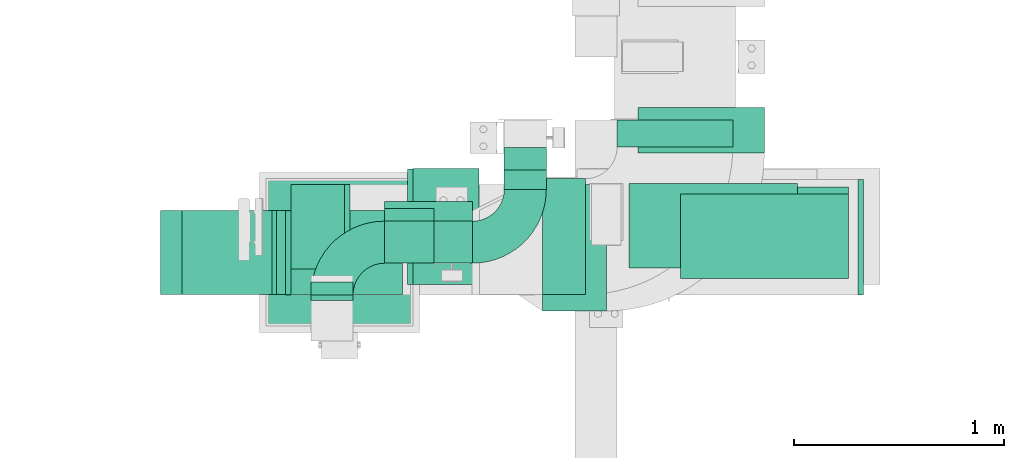
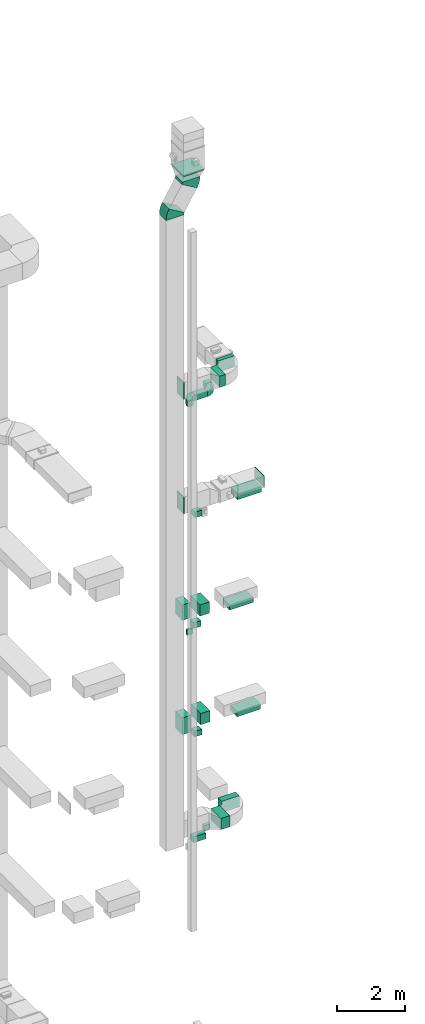
# One storey, part 11 of 29: 20 flow segments, 9 flow fittings.
"""IFC2X3 building model written with IfcOpenShell, lengths in millimetres."""

from ifc_helpers import new_model, entity, si_unit, converted_unit, derived_unit, direction, frame, frame_2d, origin, origin_2d_with_axis, place, context, subcontext, project, spatial, polyline, circle_curve, parameter, trimmed, segment, composite_curve, rectangle, outline, extrude, source, transform, mapped, material, type_object, type_shapes, element, save


model = new_model("IFC2X3")

# Units and contexts
model_context = context("Model", 3, precision=0.01, world=origin(), true_north=direction((6.12303176911189e-17, 1.0)))
body_context = subcontext(model_context, "Body", "Model", "MODEL_VIEW")
ifc_project = project(units=[si_unit("LENGTHUNIT", "METRE", prefix="MILLI"), si_unit("AREAUNIT", "SQUARE_METRE"), si_unit("VOLUMEUNIT", "CUBIC_METRE"), converted_unit("PLANEANGLEUNIT", "DEGREE", entity("IfcRatioMeasure", 0.0174532925199433), si_unit("PLANEANGLEUNIT", "RADIAN"), dimensions=[0, 0, 0, 0, 0, 0, 0]), si_unit("MASSUNIT", "GRAM", prefix="KILO"), derived_unit("MASSDENSITYUNIT", [(si_unit("MASSUNIT", "GRAM", prefix="KILO"), 1), (si_unit("LENGTHUNIT", "METRE"), -3)]), derived_unit("MOMENTOFINERTIAUNIT", [(si_unit("LENGTHUNIT", "METRE"), 4)]), si_unit("TIMEUNIT", "SECOND"), si_unit("FREQUENCYUNIT", "HERTZ"), si_unit("THERMODYNAMICTEMPERATUREUNIT", "DEGREE_CELSIUS"), derived_unit("THERMALTRANSMITTANCEUNIT", [(si_unit("MASSUNIT", "GRAM", prefix="KILO"), 1), (si_unit("THERMODYNAMICTEMPERATUREUNIT", "KELVIN"), -1), (si_unit("TIMEUNIT", "SECOND"), -3)]), derived_unit("VOLUMETRICFLOWRATEUNIT", [(si_unit("LENGTHUNIT", "METRE"), 3), (si_unit("TIMEUNIT", "SECOND"), -1)]), derived_unit("MASSFLOWRATEUNIT", [(si_unit("MASSUNIT", "GRAM", prefix="KILO"), 1), (si_unit("TIMEUNIT", "SECOND"), -1)]), derived_unit("ROTATIONALFREQUENCYUNIT", [(si_unit("TIMEUNIT", "SECOND"), -1)]), si_unit("ELECTRICCURRENTUNIT", "AMPERE"), si_unit("ELECTRICVOLTAGEUNIT", "VOLT"), si_unit("POWERUNIT", "WATT"), si_unit("FORCEUNIT", "NEWTON", prefix="KILO"), si_unit("ILLUMINANCEUNIT", "LUX"), si_unit("LUMINOUSFLUXUNIT", "LUMEN"), si_unit("LUMINOUSINTENSITYUNIT", "CANDELA"), derived_unit("USERDEFINED", [(si_unit("MASSUNIT", "GRAM", prefix="KILO"), -1), (si_unit("LENGTHUNIT", "METRE"), -2), (si_unit("TIMEUNIT", "SECOND"), 3), (si_unit("LUMINOUSFLUXUNIT", "LUMEN"), 1)]), derived_unit("LINEARVELOCITYUNIT", [(si_unit("LENGTHUNIT", "METRE"), 1), (si_unit("TIMEUNIT", "SECOND"), -1)]), si_unit("PRESSUREUNIT", "PASCAL"), derived_unit("USERDEFINED", [(si_unit("LENGTHUNIT", "METRE"), -2), (si_unit("MASSUNIT", "GRAM", prefix="KILO"), 1), (si_unit("TIMEUNIT", "SECOND"), -2)]), derived_unit("LINEARFORCEUNIT", [(si_unit("MASSUNIT", "GRAM", prefix="KILO"), 1), (si_unit("LENGTHUNIT", "METRE"), 1), (si_unit("TIMEUNIT", "SECOND"), -2), (si_unit("LENGTHUNIT", "METRE"), -1)]), derived_unit("PLANARFORCEUNIT", [(si_unit("MASSUNIT", "GRAM", prefix="KILO"), 1), (si_unit("LENGTHUNIT", "METRE"), 1), (si_unit("TIMEUNIT", "SECOND"), -2), (si_unit("LENGTHUNIT", "METRE"), -2)])], contexts=[model_context])

# Site, building, storey
site_placement = place(None, frame((0.0, -0.00077364408347762, 0.0)))
site = spatial("IfcSite", under=ifc_project, at=site_placement, CompositionType="ELEMENT")
building_placement = place(site_placement, origin())
building = spatial("IfcBuilding", under=site, at=building_placement, CompositionType="ELEMENT")
storey_placement = place(building_placement, origin())
storey = spatial("IfcBuildingStorey", under=building, at=storey_placement, CompositionType="ELEMENT", Elevation=0.0)

# Flow segments
duct_segment_type = type_object("IfcDuctSegmentType", PredefinedType="NOTDEFINED")
flow_segment_1_placement = place(storey_placement, frame((11246.0235967229, 14394.083545381, 7200.0)))
element("IfcFlowSegment", 1, at=flow_segment_1_placement, inside=storey, type_object=duct_segment_type, context=body_context, shape_type="SweptSolid", body=[
    extrude(rectangle(XDim=304.195841947545, YDim=600.0, at=frame_2d((1.09423581307055e-12, 1.08002495835535e-12), x_axis=(1.0, 0.0))), frame((152.097920973771, 300.0, 0.0), z_axis=(0.0, 0.0, 1.0), x_axis=(-1.0, 0.0, 0.0)), (0.0, 0.0, 1.0), 400.0),
])
flow_segment_2_placement = place(storey_placement, frame((11900.1283257901, 14584.0835453812, 10900.0)))
element("IfcFlowSegment", 2, at=flow_segment_2_placement, inside=storey, type_object=duct_segment_type, context=body_context, shape_type="SweptSolid", body=[
    extrude(rectangle(XDim=400.0, YDim=800.0, at=frame_2d((-2.17426077142591e-12, 0.0), x_axis=(1.0, 0.0))), frame((400.0, 200.0, 0.0), z_axis=(0.0, 0.0, 1.0), x_axis=(0.0, 1.0, 0.0)), (0.0, 0.0, 1.0), 180.000000000002),
])
flow_segment_3_placement = place(storey_placement, frame((11657.1283257901, 14599.0835453812, 14800.0)))
element("IfcFlowSegment", 3, at=flow_segment_3_placement, inside=storey, type_object=duct_segment_type, context=body_context, shape_type="SweptSolid", body=[
    extrude(rectangle(XDim=400.0, YDim=800.0, at=origin_2d_with_axis()), frame((400.0, 200.0, 0.0), z_axis=(0.0, 0.0, 1.0), x_axis=(0.0, 1.0, 0.0)), (0.0, 0.0, 1.0), 180.0),
])
flow_segment_4_placement = place(storey_placement, frame((11900.1283257901, 14549.0835453812, 18700.0)))
element("IfcFlowSegment", 4, at=flow_segment_4_placement, inside=storey, type_object=duct_segment_type, context=body_context, shape_type="SweptSolid", body=[
    extrude(rectangle(XDim=800.0, YDim=400.0, at=origin_2d_with_axis()), frame((400.0, 200.0, 0.0)), (0.0, 0.0, 1.0), 179.999999999998),
])
flow_segment_5_placement = place(storey_placement, frame((10494.7174683872, 14713.0483402227, 6800.0)))
element("IfcFlowSegment", 5, at=flow_segment_5_placement, inside=storey, type_object=duct_segment_type, context=body_context, shape_type="SweptSolid", body=[
    extrude(rectangle(XDim=418.531127100544, YDim=200.0, at=frame_2d((-1.09423581307055e-12, 0.0), x_axis=(1.0, 0.0))), frame((209.265563550273, 100.0, 0.0)), (0.0, 0.0, 1.0), 200.0),
])
flow_segment_6_placement = place(storey_placement, frame((10494.7174683872, 14620.8402530395, 10650.0)))
element("IfcFlowSegment", 6, at=flow_segment_6_placement, inside=storey, type_object=duct_segment_type, context=body_context, shape_type="SweptSolid", body=[
    extrude(rectangle(XDim=235.157017077479, YDim=200.0, at=frame_2d((-1.08002495835535e-12, 0.0), x_axis=(1.0, 0.0))), frame((117.57850853874, 100.0, 0.0), z_axis=(0.0, 0.0, 1.0), x_axis=(-1.0, 0.0, 0.0)), (0.0, 0.0, 1.0), 199.999999999998),
])
flow_segment_7_placement = place(storey_placement, frame((10494.7174683872, 14680.8402530395, 14500.0)))
element("IfcFlowSegment", 7, at=flow_segment_7_placement, inside=storey, type_object=duct_segment_type, context=body_context, shape_type="SweptSolid", body=[
    extrude(rectangle(XDim=235.157017077474, YDim=200.0, at=frame_2d((1.08002495835535e-12, 1.08713038571295e-12), x_axis=(1.0, 0.0))), frame((117.578508538736, 100.0, 0.0), z_axis=(0.0, 0.0, 1.0), x_axis=(-1.0, 0.0, 0.0)), (0.0, 0.0, 1.0), 199.999999999998),
])
flow_segment_8_placement = place(storey_placement, frame((10494.7174683872, 14620.8402530396, 18500.0)))
element("IfcFlowSegment", 8, at=flow_segment_8_placement, inside=storey, type_object=duct_segment_type, context=body_context, shape_type="SweptSolid", body=[
    extrude(rectangle(XDim=235.157017077468, YDim=200.0, at=frame_2d((0.0, -1.08713038571295e-12), x_axis=(1.0, 0.0))), frame((117.578508538734, 100.0, 0.0), z_axis=(0.0, 0.0, 1.0), x_axis=(-1.0, 0.0, 0.0)), (0.0, 0.0, 1.0), 199.999999999998),
])
flow_segment_9_placement = place(storey_placement, frame((10494.7174683872, 14620.8402530396, 22700.0)))
element("IfcFlowSegment", 9, at=flow_segment_9_placement, inside=storey, type_object=duct_segment_type, context=body_context, shape_type="SweptSolid", body=[
    extrude(rectangle(XDim=418.531127100544, YDim=200.0, at=frame_2d((-1.09423581307055e-12, 0.0), x_axis=(1.0, 0.0))), frame((209.265563550273, 100.0, 0.0)), (0.0, 0.0, 1.0), 199.999999999998),
])
flow_segment_10_placement = place(storey_placement, frame((11063.2485954877, 14970.8402530396, 22700.0)))
element("IfcFlowSegment", 10, at=flow_segment_10_placement, inside=storey, type_object=duct_segment_type, context=body_context, shape_type="SweptSolid", body=[
    extrude(rectangle(XDim=161.475899875038, YDim=200.0, at=frame_2d((-1.08713038571295e-12, 0.0), x_axis=(1.0, 0.0))), frame((100.0, 80.7379499375534, 0.0), z_axis=(0.0, 0.0, 1.0), x_axis=(0.0, -1.0, 0.0)), (0.0, 0.0, 1.0), 199.999999999998),
])
flow_segment_11_placement = place(storey_placement, frame((11063.2485954877, 15063.0483402227, 6800.0)))
element("IfcFlowSegment", 11, at=flow_segment_11_placement, inside=storey, type_object=duct_segment_type, context=body_context, shape_type="SweptSolid", body=[
    extrude(rectangle(XDim=107.332237883446, YDim=200.0, at=frame_2d((0.0, -1.08713038571295e-12), x_axis=(1.0, 0.0))), frame((100.0, 53.6661189417228, 0.0), z_axis=(0.0, 0.0, 1.0), x_axis=(0.0, 1.0, 0.0)), (0.0, 0.0, 1.0), 200.0),
])
flow_segment_12_placement = place(storey_placement, frame((10629.7340134019, 14520.0835453812, 11100.0)))
element("IfcFlowSegment", 12, at=flow_segment_12_placement, inside=storey, type_object=duct_segment_type, context=body_context, shape_type="SweptSolid", body=[
    extrude(rectangle(XDim=313.893972744042, YDim=550.000000000001, at=frame_2d((-1.09423581307055e-12, 0.0), x_axis=(1.0, 0.0))), frame((156.94698637202, 275.0, 0.0), z_axis=(0.0, 0.0, 1.0), x_axis=(-1.0, 0.0, 0.0)), (0.0, 0.0, 1.0), 400.0),
])
flow_segment_13_placement = place(storey_placement, frame((10049.7340134019, 14595.0835453813, 10900.0)))
element("IfcFlowSegment", 13, at=flow_segment_13_placement, inside=storey, type_object=duct_segment_type, context=body_context, shape_type="SweptSolid", body=[
    extrude(rectangle(XDim=279.999999999941, YDim=400.0, at=frame_2d((0.0, -2.17426077142591e-12), x_axis=(1.0, 0.0))), frame((140.0, 200.0, 0.0), z_axis=(0.0, 0.0, 1.0), x_axis=(-1.0, 0.0, 0.0)), (0.0, 0.0, 1.0), 599.999999999998),
])
flow_segment_14_placement = place(storey_placement, frame((10603.4871552698, 14519.0835453812, 15000.0)))
element("IfcFlowSegment", 14, at=flow_segment_14_placement, inside=storey, type_object=duct_segment_type, context=body_context, shape_type="SweptSolid", body=[
    extrude(rectangle(XDim=325.140823658918, YDim=550.000000000001, at=frame_2d((0.0, 2.1600499167107e-12), x_axis=(1.0, 0.0))), frame((162.570411829459, 275.0, 0.0), z_axis=(0.0, 0.0, 1.0), x_axis=(-1.0, 0.0, 0.0)), (0.0, 0.0, 1.0), 400.0),
])
flow_segment_15_placement = place(storey_placement, frame((10049.7340134019, 14594.0835453812, 15000.0)))
element("IfcFlowSegment", 15, at=flow_segment_15_placement, inside=storey, type_object=duct_segment_type, context=body_context, shape_type="SweptSolid", body=[
    extrude(rectangle(XDim=253.753141867867, YDim=400.0, at=frame_2d((1.08002495835535e-12, 0.0), x_axis=(1.0, 0.0))), frame((126.876570933934, 200.0, 0.0), z_axis=(0.0, 0.0, 1.0), x_axis=(-1.0, 0.0, 0.0)), (0.0, 0.0, 1.0), 550.000000000001),
])
flow_segment_16_placement = place(storey_placement, frame((10144.7174683872, 14470.8402530397, 14500.0)))
element("IfcFlowSegment", 16, at=flow_segment_16_placement, inside=storey, type_object=duct_segment_type, context=body_context, shape_type="SweptSolid", body=[
    extrude(rectangle(XDim=59.9999999998932, YDim=200.0, at=frame_2d((-1.08357767203415e-12, -1.08713038571295e-12), x_axis=(1.0, 0.0))), frame((100.0, 30.0, 0.0), z_axis=(0.0, 0.0, 1.0), x_axis=(0.0, 1.0, 0.0)), (0.0, 0.0, 1.0), 199.999999999998),
])
flow_segment_17_placement = place(storey_placement, frame((11599.6422610433, 15172.5640511154, 23000.0)))
element("IfcFlowSegment", 17, at=flow_segment_17_placement, inside=storey, type_object=duct_segment_type, context=body_context, shape_type="SweptSolid", body=[
    extrude(rectangle(XDim=128.921794173047, YDim=550.000000000001, at=frame_2d((1.08713038571295e-12, 0.0), x_axis=(1.0, 0.0))), frame((275.0, 64.4608970865247, 0.0), z_axis=(0.0, 0.0, 1.0), x_axis=(0.0, -1.0, 0.0)), (0.0, 0.0, 1.0), 399.999999999996),
])
flow_segment_18_placement = place(storey_placement, frame((11245.7694963104, 14472.5640511154, 23000.0)))
element("IfcFlowSegment", 18, at=flow_segment_18_placement, inside=storey, type_object=duct_segment_type, context=body_context, shape_type="SweptSolid", body=[
    extrude(rectangle(XDim=203.872764732928, YDim=550.000000000001, at=frame_2d((0.0, 1.08002495835535e-12), x_axis=(1.0, 0.0))), frame((101.936382366464, 275.0, 0.0)), (0.0, 0.0, 1.0), 399.999999999996),
])
flow_segment_19_placement = place(storey_placement, frame((11700.2194386705, 15144.0835453811, 7200.0)))
element("IfcFlowSegment", 19, at=flow_segment_19_placement, inside=storey, type_object=duct_segment_type, context=body_context, shape_type="SweptSolid", body=[
    extrude(rectangle(XDim=216.297032725026, YDim=600.0, at=frame_2d((0.0, 1.08002495835535e-12), x_axis=(1.0, 0.0))), frame((300.0, 108.148516362513, 0.0), z_axis=(0.0, 0.0, 1.0), x_axis=(0.0, -1.0, 0.0)), (0.0, 0.0, 1.0), 400.0),
])
flow_segment_20_placement = place(storey_placement, frame((9929.73401340193, 14322.5640511154, 31101.9763310467)))
element("IfcFlowSegment", 20, at=flow_segment_20_placement, inside=storey, type_object=duct_segment_type, context=body_context, shape_type="SweptSolid", body=[
    extrude(rectangle(XDim=700.000000000001, YDim=699.999999999999, at=frame_2d((-1.08002495835535e-12, 0.0), x_axis=(1.0, 0.0))), frame((350.0, 350.0, 0.0), z_axis=(0.0, 0.0, 1.0), x_axis=(0.0, 1.0, 0.0)), (0.0, 0.0, 1.0), 38.0236689533407),
])

# Flow fittings
ifc_material = material()
duct_fitting_type_1 = type_object("IfcDuctFittingType", PredefinedType="NOTDEFINED", material=ifc_material)
shared_shape_1 = source(origin(), body_context, "Body", "SweptSolid", [
    extrude(rectangle(XDim=26.0960000000012, YDim=800.0, at=frame_2d((-6.21724893790088e-13, -5.6843418860808e-14), x_axis=(1.0, 0.0))), frame((6.95199999999999, 0.0, -200.0)), (0.0, 0.0, 1.0), 400.0),
])
type_shapes(duct_fitting_type_1, [shared_shape_1])
flow_fitting_1_placement = place(storey_placement, frame((12300.1283257901, 14749.0835453812, 18900.0), z_axis=(0.0, 1.0, 0.0), x_axis=(0.0, 0.0, -1.0)))
element("IfcFlowFitting", 21, at=flow_fitting_1_placement, inside=storey, type_object=duct_fitting_type_1, material=ifc_material, context=body_context, shape_type="MappedRepresentation", body=[
    mapped(shared_shape_1, transform((0.0, 0.0, 0.0), scale=1.0)),
])
duct_fitting_type_2 = type_object("IfcDuctFittingType", PredefinedType="NOTDEFINED", material=ifc_material)
shared_shape_2 = source(origin(), body_context, "Body", "SweptSolid", [
    extrude(rectangle(XDim=24.9999999999999, YDim=550.0, at=frame_2d((-2.28261853862932e-13, 0.0), x_axis=(1.0, 0.0))), frame((12.500000000006, 0.0, -200.0)), (0.0, 0.0, 1.0), 400.0),
])
type_shapes(duct_fitting_type_2, [shared_shape_2])
flow_fitting_2_placement = place(storey_placement, frame((12745.7694963104, 14744.5640511155, 19100.0)))
element("IfcFlowFitting", 22, at=flow_fitting_2_placement, inside=storey, type_object=duct_fitting_type_2, material=ifc_material, context=body_context, shape_type="MappedRepresentation", body=[
    mapped(shared_shape_2, transform((0.0, 0.0, 0.0), scale=1.0)),
])
duct_fitting_type_3 = type_object("IfcDuctFittingType", PredefinedType="NOTDEFINED", material=ifc_material)
shared_shape_3 = source(origin(), body_context, "Body", "SweptSolid", [
    extrude(rectangle(XDim=600.0, YDim=26.096, at=origin_2d_with_axis()), frame((6.95199999999999, 0.0, -200.0), z_axis=(0.0, 0.0, 1.0), x_axis=(0.0, -1.0, 0.0)), (0.0, 0.0, 1.0), 400.0),
])
type_shapes(duct_fitting_type_3, [shared_shape_3])
for number, where, z_axis, x_axis in (
    (23, (10029.7340134019, 14669.5640511156, 19200.0), (0.0, -1.0, 0.0), (1.0, 0.0, 0.0)),
    (24, (10029.7340134019, 14672.5640511155, 23300.0), (0.0, -1.0, 0.0), (1.0, 0.0, 0.0)),
):
    element("IfcFlowFitting", number, at=place(storey_placement, frame(where, z_axis=z_axis, x_axis=x_axis)), inside=storey, type_object=duct_fitting_type_3, material=ifc_material, context=body_context, shape_type="MappedRepresentation", body=[
        mapped(shared_shape_3, transform((0.0, 0.0, 0.0), scale=1.0)),
    ])
duct_fitting_type_4 = type_object("IfcDuctFittingType", PredefinedType="NOTDEFINED", material=ifc_material)
shared_shape_4 = source(origin(), body_context, "Body", "SweptSolid", [
    extrude(outline(composite_curve([segment(polyline([(-225.0, -125.0), (-25.0, -125.0)]), True, "CONTINUOUS"), segment(trimmed(circle_curve(frame_2d((125.0, -125.0), x_axis=(0.0, 1.0)), 150.0), [parameter(0.0)], [parameter(90.0000000000001)], True, "PARAMETER"), False, "CONTINUOUS"), segment(polyline([(125.0, 25.0), (125.0, 225.0)]), True, "CONTINUOUS"), segment(trimmed(circle_curve(frame_2d((125.0, -125.0), x_axis=(0.0, 1.0)), 350.0), [parameter(0.0)], [parameter(90.0000000000001)], True, "PARAMETER"), True, "CONTINUOUS")], self_intersect=False)), frame((-125.0, 125.0, -100.0), z_axis=(0.0, 0.0, 1.0), x_axis=(-1.0, 0.0, 0.0)), (0.0, 0.0, 1.0), 200.0),
])
type_shapes(duct_fitting_type_4, [shared_shape_4])
flow_fitting_3_placement = place(storey_placement, frame((10244.7174683872, 14720.8402530396, 22800.0), z_axis=(0.0, 0.0, 1.0), x_axis=(-1.0, 0.0, 0.0)))
element("IfcFlowFitting", 25, at=flow_fitting_3_placement, inside=storey, type_object=duct_fitting_type_4, material=ifc_material, context=body_context, shape_type="MappedRepresentation", body=[
    mapped(shared_shape_4, transform((0.0, 0.0, 0.0), scale=1.0)),
])
flow_fitting_4_placement = place(storey_placement, frame((11163.2485954877, 14720.8402530396, 22800.0)))
element("IfcFlowFitting", 26, at=flow_fitting_4_placement, inside=storey, type_object=duct_fitting_type_4, material=ifc_material, context=body_context, shape_type="MappedRepresentation", body=[
    mapped(shared_shape_4, transform((0.0, 0.0, 0.0), scale=1.0)),
])
duct_fitting_type_5 = type_object("IfcDuctFittingType", PredefinedType="NOTDEFINED", material=ifc_material)
shared_shape_5 = source(origin(), body_context, "Body", "SweptSolid", [
    extrude(rectangle(XDim=26.0960000000003, YDim=200.0, at=frame_2d((-1.57207580286922e-13, -9.9475983006414e-14), x_axis=(1.0, 0.0))), frame((6.95199999999999, 0.0, -100.0)), (0.0, 0.0, 1.0), 200.0),
])
type_shapes(duct_fitting_type_5, [shared_shape_5])
flow_fitting_5_placement = place(storey_placement, frame((10244.7174683872, 14450.8402530396, 22800.0), z_axis=(1.0, 0.0, 0.0), x_axis=(0.0, 1.0, 0.0)))
element("IfcFlowFitting", 27, at=flow_fitting_5_placement, inside=storey, type_object=duct_fitting_type_5, material=ifc_material, context=body_context, shape_type="MappedRepresentation", body=[
    mapped(shared_shape_5, transform((0.0, 0.0, 0.0), scale=1.0)),
])
duct_fitting_type_6 = type_object("IfcDuctFittingType", PredefinedType="NOTDEFINED", material=ifc_material)
shared_shape_6 = source(origin(), body_context, "Body", "SweptSolid", [
    extrude(outline(composite_curve([segment(polyline([(-330.799779465861, -113.627788610408), (269.200220534139, -113.627788610408)]), True, "CONTINUOUS"), segment(trimmed(circle_curve(frame_2d((419.200220534139, -113.627788610408), x_axis=(-0.863112091262842, 0.505012393824039)), 150.0), [parameter(0.0)], [parameter(30.3321750963018)], True, "PARAMETER"), False, "CONTINUOUS"), segment(polyline([(289.733406844713, -37.8759295368027), (-228.133847912992, 265.13150675762)]), True, "CONTINUOUS"), segment(trimmed(circle_curve(frame_2d((419.200220534139, -113.627788610408), x_axis=(-0.863112091262842, 0.505012393824039)), 750.0), [parameter(0.0)], [parameter(30.3321750963018)], True, "PARAMETER"), True, "CONTINUOUS")], self_intersect=False)), frame((-8.34854243619434, 30.7997794658525, -200.0), z_axis=(0.0, 0.0, 1.0), x_axis=(-0.505012393824038, 0.863112091262841, 0.0)), (0.0, 0.0, 1.0), 400.0),
])
type_shapes(duct_fitting_type_6, [shared_shape_6])
for number, where, z_axis, x_axis in (
    (28, (10279.7340134019, 14672.5640511154, 30680.0), (0.0, 1.0, 0.0), (0.0, 0.0, -1.0)),
    (29, (9729.73401340193, 14672.5640511154, 29740.0), (0.0, 1.0, 0.0), (0.0, 0.0, 1.0)),
):
    element("IfcFlowFitting", number, at=place(storey_placement, frame(where, z_axis=z_axis, x_axis=x_axis)), inside=storey, type_object=duct_fitting_type_6, material=ifc_material, context=body_context, shape_type="MappedRepresentation", body=[
        mapped(shared_shape_6, transform((0.0, 0.0, 0.0), scale=1.0)),
    ])

save(model, "model.ifc")
